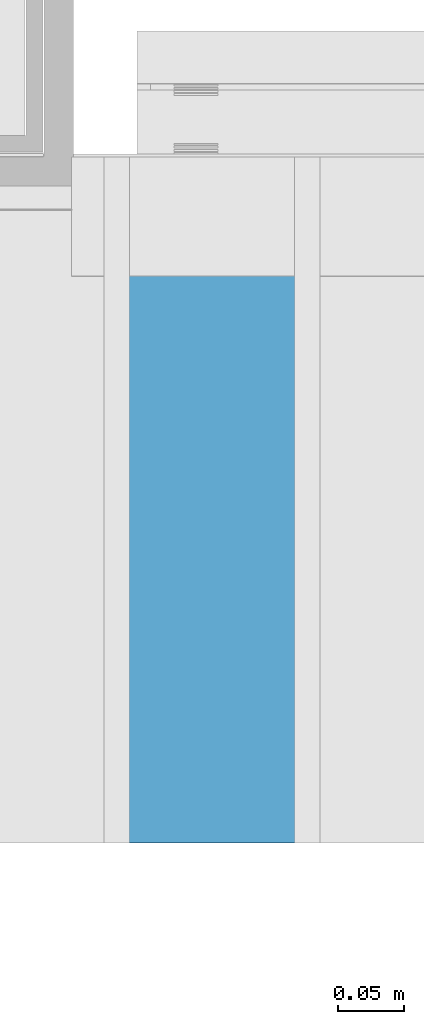
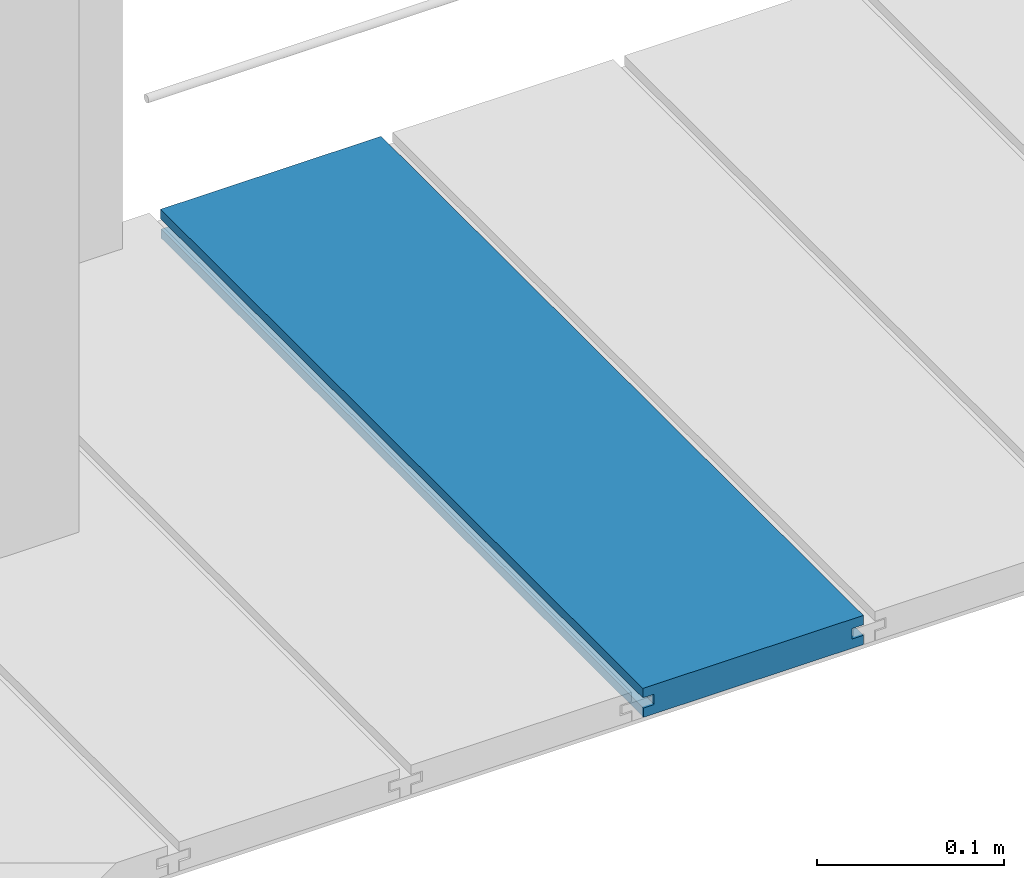
# One storey, part 18 of 33: 1 wall.
"""IFC4 building model written with IfcOpenShell, lengths in feet."""

from ifc_helpers import new_model, entity, si_unit, converted_unit, derived_unit, direction, frame, origin, place, context, subcontext, project, spatial, material, type_object, element, save


model = new_model("IFC4")

# Units and contexts
model_context = context("Model", 3, precision=0.0001, world=origin(), true_north=direction((6.12303176911189e-17, 1.0)))
body_context = subcontext(model_context, "Body", "Model", "MODEL_VIEW")
ifc_project = project(units=[converted_unit("LENGTHUNIT", "FOOT", entity("IfcRatioMeasure", 0.3048), si_unit("LENGTHUNIT", "METRE"), dimensions=[1, 0, 0, 0, 0, 0, 0]), converted_unit("AREAUNIT", "SQUARE FOOT", entity("IfcRatioMeasure", 0.09290304), si_unit("AREAUNIT", "SQUARE_METRE"), dimensions=[2, 0, 0, 0, 0, 0, 0]), converted_unit("VOLUMEUNIT", "CUBIC FOOT", entity("IfcRatioMeasure", 0.028316846592), si_unit("VOLUMEUNIT", "CUBIC_METRE"), dimensions=[3, 0, 0, 0, 0, 0, 0]), converted_unit("PLANEANGLEUNIT", "DEGREE", entity("IfcRatioMeasure", 0.0174532925199433), si_unit("PLANEANGLEUNIT", "RADIAN"), dimensions=[0, 0, 0, 0, 0, 0, 0]), si_unit("MASSUNIT", "GRAM", prefix="KILO"), derived_unit("MASSDENSITYUNIT", [(si_unit("MASSUNIT", "GRAM", prefix="KILO"), 1), (si_unit("LENGTHUNIT", "METRE"), -3)]), derived_unit("MOMENTOFINERTIAUNIT", [(si_unit("LENGTHUNIT", "METRE"), 4)]), si_unit("TIMEUNIT", "SECOND"), si_unit("FREQUENCYUNIT", "HERTZ"), si_unit("THERMODYNAMICTEMPERATUREUNIT", "DEGREE_CELSIUS"), derived_unit("THERMALTRANSMITTANCEUNIT", [(si_unit("MASSUNIT", "GRAM", prefix="KILO"), 1), (si_unit("THERMODYNAMICTEMPERATUREUNIT", "KELVIN"), -1), (si_unit("TIMEUNIT", "SECOND"), -3)]), derived_unit("VOLUMETRICFLOWRATEUNIT", [(si_unit("LENGTHUNIT", "METRE"), 3), (si_unit("TIMEUNIT", "SECOND"), -1)]), si_unit("ELECTRICCURRENTUNIT", "AMPERE"), si_unit("ELECTRICVOLTAGEUNIT", "VOLT"), si_unit("POWERUNIT", "WATT"), si_unit("FORCEUNIT", "NEWTON"), si_unit("ILLUMINANCEUNIT", "LUX"), si_unit("LUMINOUSFLUXUNIT", "LUMEN"), si_unit("LUMINOUSINTENSITYUNIT", "CANDELA"), derived_unit("USERDEFINED", [(si_unit("MASSUNIT", "GRAM", prefix="KILO"), -1), (si_unit("LENGTHUNIT", "METRE"), -2), (si_unit("TIMEUNIT", "SECOND"), 3), (si_unit("LUMINOUSFLUXUNIT", "LUMEN"), 1)]), derived_unit("LINEARVELOCITYUNIT", [(si_unit("LENGTHUNIT", "METRE"), 1), (si_unit("TIMEUNIT", "SECOND"), -1)]), si_unit("PRESSUREUNIT", "PASCAL"), derived_unit("USERDEFINED", [(si_unit("LENGTHUNIT", "METRE"), -2), (si_unit("MASSUNIT", "GRAM", prefix="KILO"), 1), (si_unit("TIMEUNIT", "SECOND"), -2)]), derived_unit("LINEARFORCEUNIT", [(si_unit("MASSUNIT", "GRAM", prefix="KILO"), 1), (si_unit("LENGTHUNIT", "METRE"), 1), (si_unit("TIMEUNIT", "SECOND"), -2), (si_unit("LENGTHUNIT", "METRE"), -1)]), derived_unit("PLANARFORCEUNIT", [(si_unit("MASSUNIT", "GRAM", prefix="KILO"), 1), (si_unit("LENGTHUNIT", "METRE"), 1), (si_unit("TIMEUNIT", "SECOND"), -2), (si_unit("LENGTHUNIT", "METRE"), -2)])], contexts=[model_context])

# Site, building, storey
site_placement = place(None, origin())
site = spatial("IfcSite", under=ifc_project, at=site_placement, CompositionType="ELEMENT")
building_placement = place(site_placement, origin())
building = spatial("IfcBuilding", under=site, at=building_placement, CompositionType="ELEMENT")
storey_placement = place(building_placement, frame((0.0, 0.0, 10.0)))
storey = spatial("IfcBuildingStorey", under=building, at=storey_placement, Name="2ND FLOOR", CompositionType="ELEMENT", Elevation=10.0000000000002)

# Wall
ifc_material = material(Name="COMPOSITE DECKING W/ HIDDEN FASTENERS", Category="Materials")
wall_type = type_object("IfcWallType", Name="Generic Models 649:Generic Models 1", PredefinedType="NOTDEFINED", material=ifc_material)
wall_placement = place(storey_placement, frame((1492.47095544867, 3.0461139299927, 0.682902157150131), z_axis=(0.0, 0.0, 1.0), x_axis=(0.0, 1.0, 0.0)))
cartesian_point_1 = entity("IfcCartesianPoint", [1.69226081335874, -0.446740923891412, 0.0])
vertex_point_1 = entity("IfcVertexPoint", cartesian_point_1)
cartesian_point_2 = entity("IfcCartesianPoint", [1.69226081335875, -0.00132475379450625, 0.0])
vertex_point_2 = entity("IfcVertexPoint", cartesian_point_2)
ifc_direction_1 = entity("IfcDirection", [0.0, 1.0, 0.0])
edge_curve_1 = entity("IfcEdgeCurve", vertex_point_1, vertex_point_2, entity("IfcTrimmedCurve", entity("IfcLine", cartesian_point_1, entity("IfcVector", ifc_direction_1, 1.0)), [cartesian_point_1], [cartesian_point_2], True, "CARTESIAN"), True)
cartesian_point_3 = entity("IfcCartesianPoint", [1.69226081335875, -0.00132475379450625, 0.0198779960861462])
vertex_point_3 = entity("IfcVertexPoint", cartesian_point_3)
ifc_direction_2 = entity("IfcDirection", [0.0, 0.0, 1.0])
edge_curve_2 = entity("IfcEdgeCurve", vertex_point_2, vertex_point_3, entity("IfcTrimmedCurve", entity("IfcLine", cartesian_point_2, entity("IfcVector", ifc_direction_2, 1.0)), [cartesian_point_2], [cartesian_point_3], True, "CARTESIAN"), True)
cartesian_point_4 = entity("IfcCartesianPoint", [1.69226081335874, -0.0228400010807945, 0.0198779960861462])
vertex_point_4 = entity("IfcVertexPoint", cartesian_point_4)
ifc_direction_3 = entity("IfcDirection", [0.0, -1.0, 0.0])
edge_curve_3 = entity("IfcEdgeCurve", vertex_point_3, vertex_point_4, entity("IfcTrimmedCurve", entity("IfcLine", cartesian_point_3, entity("IfcVector", ifc_direction_3, 1.0)), [cartesian_point_3], [cartesian_point_4], True, "CARTESIAN"), True)
cartesian_point_5 = entity("IfcCartesianPoint", [1.69226081335874, -0.0228400010807945, 0.0422987663426522])
vertex_point_5 = entity("IfcVertexPoint", cartesian_point_5)
edge_curve_4 = entity("IfcEdgeCurve", vertex_point_4, vertex_point_5, entity("IfcTrimmedCurve", entity("IfcLine", cartesian_point_4, entity("IfcVector", ifc_direction_2, 1.0)), [cartesian_point_4], [cartesian_point_5], True, "CARTESIAN"), True)
cartesian_point_6 = entity("IfcCartesianPoint", [1.69226081335875, 0.0, 0.0422987663426522])
vertex_point_6 = entity("IfcVertexPoint", cartesian_point_6)
edge_curve_5 = entity("IfcEdgeCurve", vertex_point_5, vertex_point_6, entity("IfcTrimmedCurve", entity("IfcLine", cartesian_point_5, entity("IfcVector", ifc_direction_1, 1.0)), [cartesian_point_5], [cartesian_point_6], True, "CARTESIAN"), True)
cartesian_point_7 = entity("IfcCartesianPoint", [1.69226081335875, 0.0, 0.0625000000000551])
vertex_point_7 = entity("IfcVertexPoint", cartesian_point_7)
edge_curve_6 = entity("IfcEdgeCurve", vertex_point_6, vertex_point_7, entity("IfcTrimmedCurve", entity("IfcLine", cartesian_point_6, entity("IfcVector", ifc_direction_2, 1.0)), [cartesian_point_6], [cartesian_point_7], True, "CARTESIAN"), True)
cartesian_point_8 = entity("IfcCartesianPoint", [1.69226081335874, -0.446740923891639, 0.0624999999999982])
vertex_point_8 = entity("IfcVertexPoint", cartesian_point_8)
edge_curve_7 = entity("IfcEdgeCurve", vertex_point_7, vertex_point_8, entity("IfcTrimmedCurve", entity("IfcLine", cartesian_point_7, entity("IfcVector", ifc_direction_3, 1.0)), [cartesian_point_7], [cartesian_point_8], True, "CARTESIAN"), True)
cartesian_point_9 = entity("IfcCartesianPoint", [1.69226081335874, -0.446740923891639, 0.0422987663426522])
vertex_point_9 = entity("IfcVertexPoint", cartesian_point_9)
ifc_direction_4 = entity("IfcDirection", [0.0, 0.0, -1.0])
edge_curve_8 = entity("IfcEdgeCurve", vertex_point_8, vertex_point_9, entity("IfcTrimmedCurve", entity("IfcLine", cartesian_point_8, entity("IfcVector", ifc_direction_4, 1.0)), [cartesian_point_8], [cartesian_point_9], True, "CARTESIAN"), True)
cartesian_point_10 = entity("IfcCartesianPoint", [1.69226081335874, -0.423900922810617, 0.0422987663426522])
vertex_point_10 = entity("IfcVertexPoint", cartesian_point_10)
edge_curve_9 = entity("IfcEdgeCurve", vertex_point_9, vertex_point_10, entity("IfcTrimmedCurve", entity("IfcLine", cartesian_point_9, entity("IfcVector", ifc_direction_1, 1.0)), [cartesian_point_9], [cartesian_point_10], True, "CARTESIAN"), True)
cartesian_point_11 = entity("IfcCartesianPoint", [1.69226081335874, -0.423900922810617, 0.0198779960861462])
vertex_point_11 = entity("IfcVertexPoint", cartesian_point_11)
edge_curve_10 = entity("IfcEdgeCurve", vertex_point_10, vertex_point_11, entity("IfcTrimmedCurve", entity("IfcLine", cartesian_point_10, entity("IfcVector", ifc_direction_4, 1.0)), [cartesian_point_10], [cartesian_point_11], True, "CARTESIAN"), True)
cartesian_point_12 = entity("IfcCartesianPoint", [1.69226081335874, -0.446740923891412, 0.0198779960861462])
vertex_point_12 = entity("IfcVertexPoint", cartesian_point_12)
edge_curve_11 = entity("IfcEdgeCurve", vertex_point_11, vertex_point_12, entity("IfcTrimmedCurve", entity("IfcLine", cartesian_point_11, entity("IfcVector", ifc_direction_3, 1.0)), [cartesian_point_11], [cartesian_point_12], True, "CARTESIAN"), True)
edge_curve_12 = entity("IfcEdgeCurve", vertex_point_12, vertex_point_1, entity("IfcTrimmedCurve", entity("IfcLine", cartesian_point_12, entity("IfcVector", ifc_direction_4, 1.0)), [cartesian_point_12], [cartesian_point_1], True, "CARTESIAN"), True)
ifc_direction_5 = entity("IfcDirection", [1.0, 0.0, 0.0])
cartesian_point_13 = entity("IfcCartesianPoint", [0.0, -0.446740923891412, 0.0])
vertex_point_13 = entity("IfcVertexPoint", cartesian_point_13)
cartesian_point_14 = entity("IfcCartesianPoint", [0.0, -0.446740923891412, 0.0198779960861462])
vertex_point_14 = entity("IfcVertexPoint", cartesian_point_14)
edge_curve_13 = entity("IfcEdgeCurve", vertex_point_13, vertex_point_14, entity("IfcTrimmedCurve", entity("IfcLine", cartesian_point_13, entity("IfcVector", ifc_direction_2, 1.0)), [cartesian_point_13], [cartesian_point_14], True, "CARTESIAN"), True)
cartesian_point_15 = entity("IfcCartesianPoint", [0.0, -0.423900922810617, 0.0198779960861462])
vertex_point_15 = entity("IfcVertexPoint", cartesian_point_15)
edge_curve_14 = entity("IfcEdgeCurve", vertex_point_14, vertex_point_15, entity("IfcTrimmedCurve", entity("IfcLine", cartesian_point_14, entity("IfcVector", ifc_direction_1, 1.0)), [cartesian_point_14], [cartesian_point_15], True, "CARTESIAN"), True)
cartesian_point_16 = entity("IfcCartesianPoint", [0.0, -0.423900922810617, 0.0422987663426522])
vertex_point_16 = entity("IfcVertexPoint", cartesian_point_16)
edge_curve_15 = entity("IfcEdgeCurve", vertex_point_15, vertex_point_16, entity("IfcTrimmedCurve", entity("IfcLine", cartesian_point_15, entity("IfcVector", ifc_direction_2, 1.0)), [cartesian_point_15], [cartesian_point_16], True, "CARTESIAN"), True)
cartesian_point_17 = entity("IfcCartesianPoint", [0.0, -0.446740923891639, 0.0422987663426522])
vertex_point_17 = entity("IfcVertexPoint", cartesian_point_17)
edge_curve_16 = entity("IfcEdgeCurve", vertex_point_16, vertex_point_17, entity("IfcTrimmedCurve", entity("IfcLine", cartesian_point_16, entity("IfcVector", ifc_direction_3, 1.0)), [cartesian_point_16], [cartesian_point_17], True, "CARTESIAN"), True)
cartesian_point_18 = entity("IfcCartesianPoint", [0.0, -0.446740923891639, 0.0624999999999982])
vertex_point_18 = entity("IfcVertexPoint", cartesian_point_18)
edge_curve_17 = entity("IfcEdgeCurve", vertex_point_17, vertex_point_18, entity("IfcTrimmedCurve", entity("IfcLine", cartesian_point_17, entity("IfcVector", ifc_direction_2, 1.0)), [cartesian_point_17], [cartesian_point_18], True, "CARTESIAN"), True)
cartesian_point_19 = entity("IfcCartesianPoint", [0.0, 0.0, 0.0625000000000551])
vertex_point_19 = entity("IfcVertexPoint", cartesian_point_19)
edge_curve_18 = entity("IfcEdgeCurve", vertex_point_18, vertex_point_19, entity("IfcTrimmedCurve", entity("IfcLine", cartesian_point_18, entity("IfcVector", ifc_direction_1, 1.0)), [cartesian_point_18], [cartesian_point_19], True, "CARTESIAN"), True)
cartesian_point_20 = entity("IfcCartesianPoint", [0.0, 0.0, 0.0422987663426522])
vertex_point_20 = entity("IfcVertexPoint", cartesian_point_20)
edge_curve_19 = entity("IfcEdgeCurve", vertex_point_19, vertex_point_20, entity("IfcTrimmedCurve", entity("IfcLine", cartesian_point_19, entity("IfcVector", ifc_direction_4, 1.0)), [cartesian_point_19], [cartesian_point_20], True, "CARTESIAN"), True)
cartesian_point_21 = entity("IfcCartesianPoint", [0.0, -0.0228400010807945, 0.0422987663426522])
vertex_point_21 = entity("IfcVertexPoint", cartesian_point_21)
edge_curve_20 = entity("IfcEdgeCurve", vertex_point_20, vertex_point_21, entity("IfcTrimmedCurve", entity("IfcLine", cartesian_point_20, entity("IfcVector", ifc_direction_3, 1.0)), [cartesian_point_20], [cartesian_point_21], True, "CARTESIAN"), True)
cartesian_point_22 = entity("IfcCartesianPoint", [0.0, -0.0228400010807945, 0.0198779960861462])
vertex_point_22 = entity("IfcVertexPoint", cartesian_point_22)
edge_curve_21 = entity("IfcEdgeCurve", vertex_point_21, vertex_point_22, entity("IfcTrimmedCurve", entity("IfcLine", cartesian_point_21, entity("IfcVector", ifc_direction_4, 1.0)), [cartesian_point_21], [cartesian_point_22], True, "CARTESIAN"), True)
cartesian_point_23 = entity("IfcCartesianPoint", [0.0, -0.00132475379450625, 0.0198779960861462])
vertex_point_23 = entity("IfcVertexPoint", cartesian_point_23)
edge_curve_22 = entity("IfcEdgeCurve", vertex_point_22, vertex_point_23, entity("IfcTrimmedCurve", entity("IfcLine", cartesian_point_22, entity("IfcVector", ifc_direction_1, 1.0)), [cartesian_point_22], [cartesian_point_23], True, "CARTESIAN"), True)
cartesian_point_24 = entity("IfcCartesianPoint", [0.0, -0.00132475379450625, 0.0])
vertex_point_24 = entity("IfcVertexPoint", cartesian_point_24)
edge_curve_23 = entity("IfcEdgeCurve", vertex_point_23, vertex_point_24, entity("IfcTrimmedCurve", entity("IfcLine", cartesian_point_23, entity("IfcVector", ifc_direction_4, 1.0)), [cartesian_point_23], [cartesian_point_24], True, "CARTESIAN"), True)
edge_curve_24 = entity("IfcEdgeCurve", vertex_point_24, vertex_point_13, entity("IfcTrimmedCurve", entity("IfcLine", cartesian_point_24, entity("IfcVector", ifc_direction_3, 1.0)), [cartesian_point_24], [cartesian_point_13], True, "CARTESIAN"), True)
ifc_direction_6 = entity("IfcDirection", [-1.0, 0.0, 0.0])
edge_curve_25 = entity("IfcEdgeCurve", vertex_point_13, vertex_point_1, entity("IfcTrimmedCurve", entity("IfcLine", cartesian_point_13, entity("IfcVector", ifc_direction_5, 1.0)), [cartesian_point_13], [cartesian_point_1], True, "CARTESIAN"), True)
edge_curve_26 = entity("IfcEdgeCurve", vertex_point_12, vertex_point_14, entity("IfcTrimmedCurve", entity("IfcLine", cartesian_point_14, entity("IfcVector", ifc_direction_6, 1.0)), [cartesian_point_12], [cartesian_point_14], True, "CARTESIAN"), True)
edge_curve_27 = entity("IfcEdgeCurve", vertex_point_18, vertex_point_8, entity("IfcTrimmedCurve", entity("IfcLine", cartesian_point_18, entity("IfcVector", ifc_direction_5, 1.0)), [cartesian_point_18], [cartesian_point_8], True, "CARTESIAN"), True)
edge_curve_28 = entity("IfcEdgeCurve", vertex_point_7, vertex_point_19, entity("IfcTrimmedCurve", entity("IfcLine", cartesian_point_19, entity("IfcVector", ifc_direction_6, 1.0)), [cartesian_point_7], [cartesian_point_19], True, "CARTESIAN"), True)
edge_curve_29 = entity("IfcEdgeCurve", vertex_point_6, vertex_point_20, entity("IfcTrimmedCurve", entity("IfcLine", cartesian_point_20, entity("IfcVector", ifc_direction_6, 1.0)), [cartesian_point_6], [cartesian_point_20], True, "CARTESIAN"), True)
edge_curve_30 = entity("IfcEdgeCurve", vertex_point_24, vertex_point_2, entity("IfcTrimmedCurve", entity("IfcLine", cartesian_point_24, entity("IfcVector", ifc_direction_5, 1.0)), [cartesian_point_24], [cartesian_point_2], True, "CARTESIAN"), True)
edge_curve_31 = entity("IfcEdgeCurve", vertex_point_17, vertex_point_9, entity("IfcTrimmedCurve", entity("IfcLine", cartesian_point_17, entity("IfcVector", ifc_direction_5, 1.0)), [cartesian_point_17], [cartesian_point_9], True, "CARTESIAN"), True)
edge_curve_32 = entity("IfcEdgeCurve", vertex_point_5, vertex_point_21, entity("IfcTrimmedCurve", entity("IfcLine", cartesian_point_21, entity("IfcVector", ifc_direction_6, 1.0)), [cartesian_point_5], [cartesian_point_21], True, "CARTESIAN"), True)
edge_curve_33 = entity("IfcEdgeCurve", vertex_point_4, vertex_point_22, entity("IfcTrimmedCurve", entity("IfcLine", cartesian_point_22, entity("IfcVector", ifc_direction_6, 1.0)), [cartesian_point_4], [cartesian_point_22], True, "CARTESIAN"), True)
edge_curve_34 = entity("IfcEdgeCurve", vertex_point_3, vertex_point_23, entity("IfcTrimmedCurve", entity("IfcLine", cartesian_point_23, entity("IfcVector", ifc_direction_6, 1.0)), [cartesian_point_3], [cartesian_point_23], True, "CARTESIAN"), True)
edge_curve_35 = entity("IfcEdgeCurve", vertex_point_11, vertex_point_15, entity("IfcTrimmedCurve", entity("IfcLine", cartesian_point_15, entity("IfcVector", ifc_direction_6, 1.0)), [cartesian_point_11], [cartesian_point_15], True, "CARTESIAN"), True)
edge_curve_36 = entity("IfcEdgeCurve", vertex_point_10, vertex_point_16, entity("IfcTrimmedCurve", entity("IfcLine", cartesian_point_16, entity("IfcVector", ifc_direction_6, 1.0)), [cartesian_point_10], [cartesian_point_16], True, "CARTESIAN"), True)
element("IfcWall", 1, at=wall_placement, inside=storey, type_object=wall_type, material=ifc_material, Name="Generic Models 649:Generic Models 1", ObjectType="Generic Models 649:Generic Models 1", PredefinedType="NOTDEFINED", context=body_context, shape_type="AdvancedBrep", body=[
    entity("IfcAdvancedBrep", entity("IfcClosedShell", [entity("IfcAdvancedFace", [entity("IfcFaceOuterBound", entity("IfcEdgeLoop", [entity("IfcOrientedEdge", None, None, edge_curve_1, True), entity("IfcOrientedEdge", None, None, edge_curve_2, True), entity("IfcOrientedEdge", None, None, edge_curve_3, True), entity("IfcOrientedEdge", None, None, edge_curve_4, True), entity("IfcOrientedEdge", None, None, edge_curve_5, True), entity("IfcOrientedEdge", None, None, edge_curve_6, True), entity("IfcOrientedEdge", None, None, edge_curve_7, True), entity("IfcOrientedEdge", None, None, edge_curve_8, True), entity("IfcOrientedEdge", None, None, edge_curve_9, True), entity("IfcOrientedEdge", None, None, edge_curve_10, True), entity("IfcOrientedEdge", None, None, edge_curve_11, True), entity("IfcOrientedEdge", None, None, edge_curve_12, True)]), True)], entity("IfcPlane", entity("IfcAxis2Placement3D", entity("IfcCartesianPoint", [1.69226081335874, -0.446740923891412, -0.0208333333328241]), ifc_direction_5, ifc_direction_4)), True), entity("IfcAdvancedFace", [entity("IfcFaceOuterBound", entity("IfcEdgeLoop", [entity("IfcOrientedEdge", None, None, edge_curve_13, True), entity("IfcOrientedEdge", None, None, edge_curve_14, True), entity("IfcOrientedEdge", None, None, edge_curve_15, True), entity("IfcOrientedEdge", None, None, edge_curve_16, True), entity("IfcOrientedEdge", None, None, edge_curve_17, True), entity("IfcOrientedEdge", None, None, edge_curve_18, True), entity("IfcOrientedEdge", None, None, edge_curve_19, True), entity("IfcOrientedEdge", None, None, edge_curve_20, True), entity("IfcOrientedEdge", None, None, edge_curve_21, True), entity("IfcOrientedEdge", None, None, edge_curve_22, True), entity("IfcOrientedEdge", None, None, edge_curve_23, True), entity("IfcOrientedEdge", None, None, edge_curve_24, True)]), True)], entity("IfcPlane", entity("IfcAxis2Placement3D", entity("IfcCartesianPoint", [0.0, -0.446740923891412, -0.0208333333328241]), ifc_direction_6, ifc_direction_2)), True), entity("IfcAdvancedFace", [entity("IfcFaceOuterBound", entity("IfcEdgeLoop", [entity("IfcOrientedEdge", None, None, edge_curve_13, False), entity("IfcOrientedEdge", None, None, edge_curve_25, True), entity("IfcOrientedEdge", None, None, edge_curve_12, False), entity("IfcOrientedEdge", None, None, edge_curve_26, True)]), True)], entity("IfcPlane", entity("IfcAxis2Placement3D", cartesian_point_13, ifc_direction_3, ifc_direction_5)), True), entity("IfcAdvancedFace", [entity("IfcFaceOuterBound", entity("IfcEdgeLoop", [entity("IfcOrientedEdge", None, None, edge_curve_18, False), entity("IfcOrientedEdge", None, None, edge_curve_27, True), entity("IfcOrientedEdge", None, None, edge_curve_7, False), entity("IfcOrientedEdge", None, None, edge_curve_28, True)]), True)], entity("IfcPlane", entity("IfcAxis2Placement3D", cartesian_point_18, ifc_direction_2, ifc_direction_5)), True), entity("IfcAdvancedFace", [entity("IfcFaceOuterBound", entity("IfcEdgeLoop", [entity("IfcOrientedEdge", None, None, edge_curve_19, False), entity("IfcOrientedEdge", None, None, edge_curve_28, False), entity("IfcOrientedEdge", None, None, edge_curve_6, False), entity("IfcOrientedEdge", None, None, edge_curve_29, True)]), True)], entity("IfcPlane", entity("IfcAxis2Placement3D", cartesian_point_19, ifc_direction_1, ifc_direction_5)), True), entity("IfcAdvancedFace", [entity("IfcFaceOuterBound", entity("IfcEdgeLoop", [entity("IfcOrientedEdge", None, None, edge_curve_24, False), entity("IfcOrientedEdge", None, None, edge_curve_30, True), entity("IfcOrientedEdge", None, None, edge_curve_1, False), entity("IfcOrientedEdge", None, None, edge_curve_25, False)]), True)], entity("IfcPlane", entity("IfcAxis2Placement3D", cartesian_point_24, ifc_direction_4, ifc_direction_5)), True), entity("IfcAdvancedFace", [entity("IfcFaceOuterBound", entity("IfcEdgeLoop", [entity("IfcOrientedEdge", None, None, edge_curve_17, False), entity("IfcOrientedEdge", None, None, edge_curve_31, True), entity("IfcOrientedEdge", None, None, edge_curve_8, False), entity("IfcOrientedEdge", None, None, edge_curve_27, False)]), True)], entity("IfcPlane", entity("IfcAxis2Placement3D", cartesian_point_17, ifc_direction_3, ifc_direction_5)), True), entity("IfcAdvancedFace", [entity("IfcFaceOuterBound", entity("IfcEdgeLoop", [entity("IfcOrientedEdge", None, None, edge_curve_20, False), entity("IfcOrientedEdge", None, None, edge_curve_29, False), entity("IfcOrientedEdge", None, None, edge_curve_5, False), entity("IfcOrientedEdge", None, None, edge_curve_32, True)]), True)], entity("IfcPlane", entity("IfcAxis2Placement3D", cartesian_point_20, ifc_direction_4, ifc_direction_5)), True), entity("IfcAdvancedFace", [entity("IfcFaceOuterBound", entity("IfcEdgeLoop", [entity("IfcOrientedEdge", None, None, edge_curve_21, False), entity("IfcOrientedEdge", None, None, edge_curve_32, False), entity("IfcOrientedEdge", None, None, edge_curve_4, False), entity("IfcOrientedEdge", None, None, edge_curve_33, True)]), True)], entity("IfcPlane", entity("IfcAxis2Placement3D", cartesian_point_21, ifc_direction_1, ifc_direction_5)), True), entity("IfcAdvancedFace", [entity("IfcFaceOuterBound", entity("IfcEdgeLoop", [entity("IfcOrientedEdge", None, None, edge_curve_22, False), entity("IfcOrientedEdge", None, None, edge_curve_33, False), entity("IfcOrientedEdge", None, None, edge_curve_3, False), entity("IfcOrientedEdge", None, None, edge_curve_34, True)]), True)], entity("IfcPlane", entity("IfcAxis2Placement3D", cartesian_point_22, ifc_direction_2, ifc_direction_5)), True), entity("IfcAdvancedFace", [entity("IfcFaceOuterBound", entity("IfcEdgeLoop", [entity("IfcOrientedEdge", None, None, edge_curve_23, False), entity("IfcOrientedEdge", None, None, edge_curve_34, False), entity("IfcOrientedEdge", None, None, edge_curve_2, False), entity("IfcOrientedEdge", None, None, edge_curve_30, False)]), True)], entity("IfcPlane", entity("IfcAxis2Placement3D", cartesian_point_23, ifc_direction_1, ifc_direction_5)), True), entity("IfcAdvancedFace", [entity("IfcFaceOuterBound", entity("IfcEdgeLoop", [entity("IfcOrientedEdge", None, None, edge_curve_14, False), entity("IfcOrientedEdge", None, None, edge_curve_26, False), entity("IfcOrientedEdge", None, None, edge_curve_11, False), entity("IfcOrientedEdge", None, None, edge_curve_35, True)]), True)], entity("IfcPlane", entity("IfcAxis2Placement3D", cartesian_point_14, ifc_direction_2, ifc_direction_5)), True), entity("IfcAdvancedFace", [entity("IfcFaceOuterBound", entity("IfcEdgeLoop", [entity("IfcOrientedEdge", None, None, edge_curve_15, False), entity("IfcOrientedEdge", None, None, edge_curve_35, False), entity("IfcOrientedEdge", None, None, edge_curve_10, False), entity("IfcOrientedEdge", None, None, edge_curve_36, True)]), True)], entity("IfcPlane", entity("IfcAxis2Placement3D", cartesian_point_15, ifc_direction_3, ifc_direction_5)), True), entity("IfcAdvancedFace", [entity("IfcFaceOuterBound", entity("IfcEdgeLoop", [entity("IfcOrientedEdge", None, None, edge_curve_16, False), entity("IfcOrientedEdge", None, None, edge_curve_36, False), entity("IfcOrientedEdge", None, None, edge_curve_9, False), entity("IfcOrientedEdge", None, None, edge_curve_31, False)]), True)], entity("IfcPlane", entity("IfcAxis2Placement3D", cartesian_point_16, ifc_direction_4, ifc_direction_5)), True)])),
])

save(model, "model.ifc")
